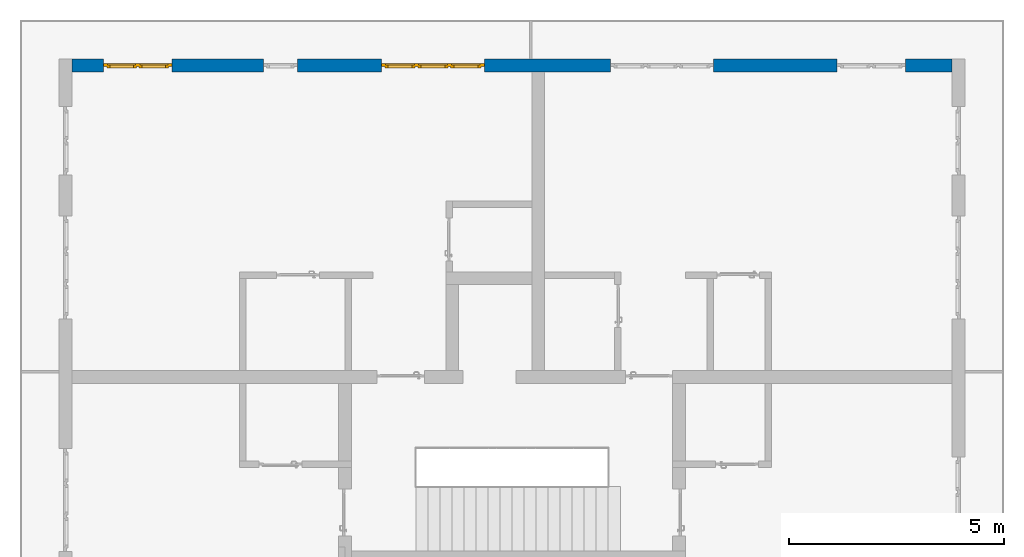
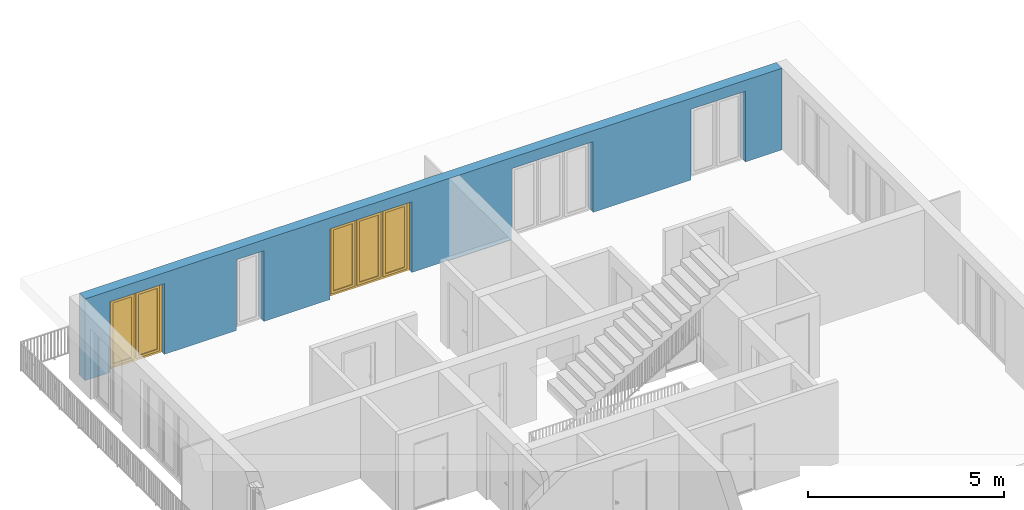
# One storey, part 21 of 48: 2 windows, 1 wall, 5 openings.
"""IFC4 building model written with IfcOpenShell, lengths in metres."""

import ifcopenshell
import ifcopenshell.guid

model = None  # the IFC model being written
_history = None  # IfcOwnerHistory: only IFC2X3 demands one
_inside = {}  # id of a spatial element -> (the spatial element, [elements in it])
_under = {}  # id of a project, library or spatial element -> (it, [spatial elements below it])
_declared = {}  # id of a project -> (the project, [libraries it declares])
_typed = {}  # id of a type object -> (the type object, [elements of that type])
_made_of = {}  # id of a material, layer set ... -> (it, [elements and type objects made of it])


def new_model(schema):
    """Start an empty IFC model of exactly this schema.

    Asked for "IFC4X3", IfcOpenShell would pick the latest addendum, in which some entities
    have other attributes; the version numbers below select the first issue.
    IFC2X3 requires an IfcOwnerHistory on every rooted entity: one is made here for all.
    """
    global model, _history
    if schema == "IFC4X3":
        model = ifcopenshell.file(schema_version=(4, 3, 0, 0))
    else:
        model = ifcopenshell.file(schema=schema)
    _inside.clear()
    _under.clear()
    _declared.clear()
    _typed.clear()
    _made_of.clear()
    _history = None
    if model.schema == "IFC2X3":
        org = make("IfcOrganization", Name="unknown")
        user = make(
            "IfcPersonAndOrganization",
            ThePerson=make("IfcPerson", FamilyName="unknown"),
            TheOrganization=org,
        )
        app = make(
            "IfcApplication",
            ApplicationDeveloper=org,
            Version="unknown",
            ApplicationFullName="unknown",
            ApplicationIdentifier="unknown",
        )
        _history = make(
            "IfcOwnerHistory",
            OwningUser=user,
            OwningApplication=app,
            ChangeAction="ADDED",
            CreationDate=0,
        )
    return model


def make(cls, **values):
    """One entity of the class cls with the attributes given. An attribute that is None is left unset."""
    return model.create_entity(
        cls, **{name: value for name, value in values.items() if value is not None}
    )


def entity(cls, *values):
    """Any entity or typed value of the class cls, its attributes in the order of the schema. None: left unset."""
    e = model.create_entity(cls)
    for i, value in enumerate(values):
        if value is not None:
            e[i] = value
    return e


def rooted(cls, **values):
    """An entity with a GlobalId (a new one), such as an element, a storey or a relation."""
    return make(cls, GlobalId=ifcopenshell.guid.new(), OwnerHistory=_history, **values)


def si_unit(unit_type, name, prefix=None):
    """IfcSIUnit, for example si_unit("LENGTHUNIT", "METRE", prefix="MILLI")."""
    return make("IfcSIUnit", UnitType=unit_type, Prefix=prefix, Name=name)


def converted_unit(unit_type, name, factor, base, dimensions=None, offset=None):
    """IfcConversionBasedUnit, such as the inch: factor (a typed value) times the base unit."""
    return make(
        "IfcConversionBasedUnit"
        if offset is None
        else "IfcConversionBasedUnitWithOffset",
        ConversionOffset=offset,
        Dimensions=None
        if dimensions is None
        else entity("IfcDimensionalExponents", *dimensions),
        UnitType=unit_type,
        Name=name,
        ConversionFactor=make(
            "IfcMeasureWithUnit", ValueComponent=factor, UnitComponent=base
        ),
    )


def derived_unit(unit_type, elements):
    """IfcDerivedUnit: a product of units, each with its exponent."""
    return make(
        "IfcDerivedUnit",
        Elements=[
            make("IfcDerivedUnitElement", Unit=unit, Exponent=power)
            for unit, power in elements
        ],
        UnitType=unit_type,
    )


def assignment(units):
    """IfcUnitAssignment: the units of a project."""
    return None if units is None else make("IfcUnitAssignment", Units=units)


def point(xyz):
    """IfcCartesianPoint."""
    return None if xyz is None else make("IfcCartesianPoint", Coordinates=xyz)


def direction(xyz):
    """IfcDirection."""
    return None if xyz is None else make("IfcDirection", DirectionRatios=xyz)


def frame(location, z_axis=None, x_axis=None):
    """IfcAxis2Placement3D, a coordinate frame: its origin and axes. An axis left out is left unset."""
    return make(
        "IfcAxis2Placement3D",
        Location=point(location),
        Axis=direction(z_axis),
        RefDirection=direction(x_axis),
    )


def origin_with_axes():
    """The frame at (0, 0, 0) with the z axis (0, 0, 1) and the x axis (1, 0, 0) written out."""
    return frame((0.0, 0.0, 0.0), z_axis=(0.0, 0.0, 1.0), x_axis=(1.0, 0.0, 0.0))


def place(relative_to, where):
    """IfcLocalPlacement: puts the frame where relative to a parent placement (None: the world)."""
    return make(
        "IfcLocalPlacement", PlacementRelTo=relative_to, RelativePlacement=where
    )


def context(
    kind, dimensions, precision=None, world=None, true_north=None, identifier=None
):
    """IfcGeometricRepresentationContext, for example the 3D "Model" context."""
    return make(
        "IfcGeometricRepresentationContext",
        ContextIdentifier=identifier,
        ContextType=kind,
        CoordinateSpaceDimension=dimensions,
        Precision=precision,
        WorldCoordinateSystem=world,
        TrueNorth=true_north,
    )


def subcontext(parent, identifier, kind, view, scale=None):
    """IfcGeometricRepresentationSubContext, for example "Body" below "Model"."""
    return make(
        "IfcGeometricRepresentationSubContext",
        ContextIdentifier=identifier,
        ContextType=kind,
        ParentContext=parent,
        TargetScale=scale,
        TargetView=view,
    )


def project(units=None, contexts=None):
    """IfcProject with its units and contexts."""
    return rooted(
        "IfcProject",
        Name="project",
        RepresentationContexts=contexts,
        UnitsInContext=assignment(units),
    )


def spatial(cls, under=None, at=None, **own):
    """A site, building, storey or space (cls), placed at a placement, below another one or the project."""
    s = rooted(cls, ObjectPlacement=at, **own)
    if under is not None:
        _under.setdefault(under.id(), (under, []))[1].append(s)
    return s


def point_list(points):
    """IfcCartesianPointList2D or 3D."""
    cls = (
        "IfcCartesianPointList2D" if len(points[0]) == 2 else "IfcCartesianPointList3D"
    )
    return make(cls, CoordList=points)


def polygons(points, faces, closed=None, point_numbers=None):
    """IfcPolygonalFaceSet: a face is its outer loop, then its inner loops; points numbered from 1."""
    made = []
    for loops in faces:
        if len(loops) == 1:
            made.append(make("IfcIndexedPolygonalFace", CoordIndex=loops[0]))
        else:
            made.append(
                make(
                    "IfcIndexedPolygonalFaceWithVoids",
                    CoordIndex=loops[0],
                    InnerCoordIndices=loops[1:],
                )
            )
    return make(
        "IfcPolygonalFaceSet",
        Coordinates=point_list(points),
        Closed=closed,
        Faces=made,
        PnIndex=point_numbers,
    )


def shape(context_of_items, identifier, shape_type, items):
    """IfcShapeRepresentation: the items that make up one representation, for example the "Body"."""
    return make(
        "IfcShapeRepresentation",
        ContextOfItems=context_of_items,
        RepresentationIdentifier=identifier,
        RepresentationType=shape_type,
        Items=items,
    )


def source(mapping_origin, context_of_items, identifier, shape_type, items):
    """IfcRepresentationMap: a shape defined once, which mapped items show again and again."""
    return make(
        "IfcRepresentationMap",
        MappingOrigin=mapping_origin,
        MappedRepresentation=shape(context_of_items, identifier, shape_type, items),
    )


def transform(
    local_origin,
    x_axis=None,
    y_axis=None,
    z_axis=None,
    scale=None,
    scale2=None,
    scale3=None,
    uniform=True,
):
    """IfcCartesianTransformationOperator3D, or its non-uniform kind. x_axis, y_axis, z_axis: its Axis1, 2, 3."""
    if uniform:
        return make(
            "IfcCartesianTransformationOperator3D",
            Axis1=direction(x_axis),
            Axis2=direction(y_axis),
            LocalOrigin=point(local_origin),
            Scale=scale,
            Axis3=direction(z_axis),
        )
    return make(
        "IfcCartesianTransformationOperator3DnonUniform",
        Axis1=direction(x_axis),
        Axis2=direction(y_axis),
        LocalOrigin=point(local_origin),
        Scale=scale,
        Axis3=direction(z_axis),
        Scale2=scale2,
        Scale3=scale3,
    )


def mapped(mapping_source, mapping_target):
    """IfcMappedItem: shows the shape of a source again, moved by a transform."""
    return make(
        "IfcMappedItem", MappingSource=mapping_source, MappingTarget=mapping_target
    )


def material(Name=None, Category=None):
    """IfcMaterial."""
    return make("IfcMaterial", Name=Name, Category=Category)


def made_of(thing, what):
    """Note that an element or type object is made of a material, layer set ...; save() writes the relation."""
    if what is not None:
        _made_of.setdefault(what.id(), (what, []))[1].append(thing)
    return thing


def type_object(cls, material=None, **own):
    """A type object (cls), such as IfcWallType, which elements share."""
    return made_of(rooted(cls, **own), material)


def element(
    cls,
    number,
    at=None,
    inside=None,
    cuts=None,
    type_object=None,
    material=None,
    context=None,
    identifier="Body",
    shape_type=None,
    held_by="IfcProductDefinitionShape",
    body=None,
    shapes=None,
    **own,
):
    """One element of the class cls, such as IfcWall. Its Tag is "e" and its number.

    at: its placement. inside: the storey or other place that contains it. cuts: it is an
    opening in that element (IfcRelVoidsElement). A single representation is given by context,
    identifier, shape_type and body (its items); several are given by shapes. held_by: the class
    of the entity that holds the representations. save() writes the other relations.
    """
    e = rooted(cls, Tag="e%d" % number, ObjectPlacement=at, **own)
    if body is not None:
        shapes = [shape(context, identifier, shape_type, body)]
    if shapes is not None:
        e.Representation = make(held_by, Representations=shapes)
    if inside is not None:
        _inside.setdefault(inside.id(), (inside, []))[1].append(e)
    if cuts is not None:
        rooted(
            "IfcRelVoidsElement", RelatingBuildingElement=cuts, RelatedOpeningElement=e
        )
    if type_object is not None:
        _typed.setdefault(type_object.id(), (type_object, []))[1].append(e)
    return made_of(e, material)


def fill(opening, filler):
    """IfcRelFillsElement: the door or window that sits in an opening."""
    return rooted(
        "IfcRelFillsElement",
        RelatingOpeningElement=opening,
        RelatedBuildingElement=filler,
    )


def aggregate(whole, parts):
    """IfcRelAggregates: a whole, such as a stair, and the parts it consists of."""
    return rooted("IfcRelAggregates", RelatingObject=whole, RelatedObjects=parts)


def save(model, path):
    """Write the relations noted so far, then the file.

    IfcRelAggregates (storeys below a building ...), IfcRelContainedInSpatialStructure (elements
    in a storey), IfcRelDefinesByType, IfcRelAssociatesMaterial and IfcRelDeclares: one each for
    every whole, place, type object, material and project.
    """
    for whole, parts in _under.values():
        aggregate(whole, parts)
    for where, things in _inside.values():
        rooted(
            "IfcRelContainedInSpatialStructure",
            RelatedElements=things,
            RelatingStructure=where,
        )
    for kind, things in _typed.values():
        rooted("IfcRelDefinesByType", RelatedObjects=things, RelatingType=kind)
    for what, things in _made_of.values():
        rooted("IfcRelAssociatesMaterial", RelatedObjects=things, RelatingMaterial=what)
    for by, libraries in _declared.values():
        rooted("IfcRelDeclares", RelatingContext=by, RelatedDefinitions=libraries)
    model.write(path)


model = new_model("IFC4")

# Units and contexts
model_context = context("Model", 3, precision=1e-05, world=origin_with_axes(), true_north=direction((0.0, 1.0)))
body_context = subcontext(model_context, "Body", "Model", "MODEL_VIEW")
ifc_project = project(units=[si_unit("LENGTHUNIT", "METRE"), si_unit("AREAUNIT", "SQUARE_METRE"), si_unit("VOLUMEUNIT", "CUBIC_METRE"), converted_unit("PLANEANGLEUNIT", "DEGREE", entity("IfcPlaneAngleMeasure", 0.0174532925199), si_unit("PLANEANGLEUNIT", "RADIAN"), dimensions=[0, 0, 0, 0, 0, 0, 0]), converted_unit("TIMEUNIT", "Year", entity("IfcTimeMeasure", 31556926.0), si_unit("TIMEUNIT", "SECOND"), dimensions=[0, 0, 1, 0, 0, 0, 0]), si_unit("MASSUNIT", "GRAM", prefix="KILO"), si_unit("THERMODYNAMICTEMPERATUREUNIT", "DEGREE_CELSIUS"), si_unit("LUMINOUSINTENSITYUNIT", "LUMEN"), si_unit("ENERGYUNIT", "JOULE", prefix="MEGA"), derived_unit("THERMALCONDUCTANCEUNIT", [(si_unit("POWERUNIT", "WATT"), 1), (si_unit("LENGTHUNIT", "METRE"), -1), (si_unit("THERMODYNAMICTEMPERATUREUNIT", "KELVIN"), -1)]), derived_unit("SPECIFICHEATCAPACITYUNIT", [(si_unit("ENERGYUNIT", "JOULE"), 1), (si_unit("MASSUNIT", "GRAM", prefix="KILO"), -1), (si_unit("THERMODYNAMICTEMPERATUREUNIT", "KELVIN"), -1)]), derived_unit("MASSDENSITYUNIT", [(si_unit("MASSUNIT", "GRAM", prefix="KILO"), 1), (si_unit("VOLUMEUNIT", "CUBIC_METRE"), -1)])], contexts=[model_context])

# Site, building, storey
site_placement = place(None, origin_with_axes())
site = spatial("IfcSite", under=ifc_project, at=site_placement, CompositionType="ELEMENT")
building_placement = place(site_placement, origin_with_axes())
building = spatial("IfcBuilding", under=site, at=building_placement, CompositionType="ELEMENT")
storey_placement = place(building_placement, frame((0.0, 0.0, 3.4), z_axis=(0.0, 0.0, 1.0), x_axis=(1.0, 0.0, 0.0)))
storey = spatial("IfcBuildingStorey", under=building, at=storey_placement, Name="1. Geschoss", CompositionType="ELEMENT", Elevation=3.4)

# Wall, openings, windows
ifc_material = material()
wall_type = type_object("IfcWallType", Name="300", PredefinedType="NOTDEFINED")
wall_placement = place(storey_placement, frame((-11.7421993804, 8.92118776896, 0.0), z_axis=(0.0, 0.0, 1.0), x_axis=(1.0, 0.0, 0.0)))
wall = element("IfcWall", 1, at=wall_placement, inside=storey, type_object=wall_type, material=ifc_material, Name="Wand-001", PredefinedType="NOTDEFINED", context=body_context, shape_type="Tessellation", body=[
    polygons([(15.23, -0.1, 0.0), (15.23, -0.3, 0.0), (15.23, -0.3, 2.2), (15.23, 0.0, 2.2), (15.23, 0.0, 0.0), (18.102139809, 0.0, 0.0), (18.102139809, -0.3, 0.0), (18.102139809, -0.3, 2.2), (19.702139809, -0.3, 2.2), (19.702139809, -0.3, 0.0), (20.78, -0.3, 0.0), (20.78, -0.3, 2.54), (0.3, -0.3, 2.54), (0.3, -0.3, 0.0), (1.0288518641, -0.3, 0.0), (1.0288518641, -0.3, 2.2), (2.6288518641, -0.3, 2.2), (2.6288518641, -0.3, 0.0), (4.75, -0.3, 0.0), (4.75, -0.3, 2.2), (5.55, -0.3, 2.2), (5.55, -0.3, 0.0), (7.50089858046, -0.3, 0.0), (7.50089858046, -0.3, 2.2), (9.90089858046, -0.3, 2.2), (9.90089858046, -0.3, 0.0), (12.83, -0.3, 0.0), (12.83, -0.3, 2.2), (12.83, 0.0, 2.2), (12.83, 0.0, 0.0), (9.90089858046, 0.0, 0.0), (9.90089858046, 0.0, 2.2), (7.50089858046, 0.0, 2.2), (7.50089858046, 0.0, 0.0), (5.55, 0.0, 0.0), (5.55, 0.0, 2.2), (4.75, 0.0, 2.2), (4.75, 0.0, 0.0), (2.6288518641, 0.0, 0.0), (2.6288518641, 0.0, 2.2), (1.0288518641, 0.0, 2.2), (1.0288518641, 0.0, 0.0), (0.3, 0.0, 0.0), (0.3, 0.0, 2.54), (20.78, 0.0, 2.54), (20.78, 0.0, 0.0), (19.702139809, 0.0, 0.0), (19.702139809, 0.0, 2.2), (18.102139809, 0.0, 2.2), (12.83, -0.1, 0.0)], [[[1, 2, 3, 4, 5]], [[2, 1, 5, 6, 7]], [[3, 2, 7, 8, 9, 10, 11, 12, 13, 14, 15, 16, 17, 18, 19, 20, 21, 22, 23, 24, 25, 26, 27, 28]], [[4, 3, 28, 29]], [[6, 5, 4, 29, 30, 31, 32, 33, 34, 35, 36, 37, 38, 39, 40, 41, 42, 43, 44, 45, 46, 47, 48, 49]], [[6, 49, 8, 7]], [[8, 49, 48, 9]], [[48, 47, 10, 9]], [[46, 11, 10, 47]], [[12, 11, 46, 45]], [[45, 44, 13, 12]], [[44, 43, 14, 13]], [[15, 14, 43, 42]], [[16, 15, 42, 41]], [[40, 17, 16, 41]], [[18, 17, 40, 39]], [[19, 18, 39, 38]], [[20, 19, 38, 37]], [[36, 21, 20, 37]], [[22, 21, 36, 35]], [[22, 35, 34, 23]], [[34, 33, 24, 23]], [[24, 33, 32, 25]], [[32, 31, 26, 25]], [[50, 27, 26, 31, 30]], [[28, 27, 50, 30, 29]]], closed=True),
])
opening_1_placement = place(wall_placement, frame((1.8288518641, 0.0, 0.0), z_axis=(0.0, 0.0, 1.0), x_axis=(1.0, 0.0, 0.0)))
opening_1 = element("IfcOpeningElement", 2, at=opening_1_placement, cuts=wall, Name="Fenster-001", context=body_context, identifier="Reference", shape_type="Tessellation", body=[
    polygons([(-0.8, -0.1, 0.0), (-0.8, -0.1, 2.2), (-0.8, 0.000999999999998, 2.2), (-0.8, 0.000999999999998, 0.0), (-0.8, -0.301, 0.0), (-0.8, -0.301, 2.2), (0.8, -0.1, 2.2), (0.8, 0.000999999999999, 2.2), (0.8, -0.301, 2.2), (0.8, 0.000999999999999, 0.0), (0.8, -0.1, 0.0), (0.8, -0.301, 0.0)], [[[1, 2, 3, 4]], [[2, 1, 5, 6]], [[7, 8, 3, 2, 6, 9]], [[8, 10, 4, 3]], [[1, 4, 10, 11, 12, 5]], [[6, 5, 12, 9]], [[7, 11, 10, 8]], [[11, 7, 9, 12]]], closed=True),
])
opening_2_placement = place(wall_placement, frame((8.70089858046, 0.0, 0.0), z_axis=(0.0, 0.0, 1.0), x_axis=(1.0, 0.0, 0.0)))
opening_2 = element("IfcOpeningElement", 3, at=opening_2_placement, cuts=wall, Name="Fenster-002", context=body_context, identifier="Reference", shape_type="Tessellation", body=[
    polygons([(-1.2, -0.1, 0.0), (-1.2, -0.1, 2.2), (-1.2, 0.000999999999999, 2.2), (-1.2, 0.000999999999999, 0.0), (-1.2, -0.301, 0.0), (-1.2, -0.301, 2.2), (1.2, -0.1, 2.2), (1.2, 0.001, 2.2), (1.2, -0.301, 2.2), (1.2, 0.001, 0.0), (1.2, -0.1, 0.0), (1.2, -0.301, 0.0)], [[[1, 2, 3, 4]], [[2, 1, 5, 6]], [[7, 8, 3, 2, 6, 9]], [[8, 10, 4, 3]], [[1, 4, 10, 11, 12, 5]], [[6, 5, 12, 9]], [[7, 11, 10, 8]], [[11, 7, 9, 12]]], closed=True),
])
opening_3_placement = place(wall_placement, frame((5.15, 0.0, 0.0), z_axis=(0.0, 0.0, 1.0), x_axis=(1.0, 0.0, 0.0)))
element("IfcOpeningElement", 4, at=opening_3_placement, cuts=wall, Name="Fenster-003", context=body_context, identifier="Reference", shape_type="Tessellation", body=[
    polygons([(-0.4, -0.1, 0.0), (-0.4, -0.1, 2.2), (-0.4, 0.001, 2.2), (-0.4, 0.001, 0.0), (-0.4, -0.301, 0.0), (-0.4, -0.301, 2.2), (0.4, -0.1, 2.2), (0.4, 0.001, 2.2), (0.4, -0.301, 2.2), (0.4, 0.001, 0.0), (0.4, -0.1, 0.0), (0.4, -0.301, 0.0)], [[[1, 2, 3, 4]], [[2, 1, 5, 6]], [[7, 8, 3, 2, 6, 9]], [[8, 10, 4, 3]], [[1, 4, 10, 11, 12, 5]], [[6, 5, 12, 9]], [[7, 11, 10, 8]], [[11, 7, 9, 12]]], closed=True),
])
opening_4_placement = place(wall_placement, frame((18.902139809, 0.0, 0.0), z_axis=(0.0, 0.0, 1.0), x_axis=(1.0, 0.0, 0.0)))
element("IfcOpeningElement", 5, at=opening_4_placement, cuts=wall, Name="Fenster-001", context=body_context, identifier="Reference", shape_type="Tessellation", body=[
    polygons([(-0.8, -0.1, 0.0), (-0.8, -0.1, 2.2), (-0.8, 0.001, 2.2), (-0.8, 0.001, 0.0), (-0.8, -0.301, 0.0), (-0.8, -0.301, 2.2), (0.8, -0.1, 2.2), (0.8, 0.001, 2.2), (0.8, -0.301, 2.2), (0.8, 0.001, 0.0), (0.8, -0.1, 0.0), (0.8, -0.301, 0.0)], [[[1, 2, 3, 4]], [[2, 1, 5, 6]], [[7, 8, 3, 2, 6, 9]], [[8, 10, 4, 3]], [[1, 4, 10, 11, 12, 5]], [[6, 5, 12, 9]], [[7, 11, 10, 8]], [[11, 7, 9, 12]]], closed=True),
])
opening_5_placement = place(wall_placement, frame((14.03, 0.0, 0.0), z_axis=(0.0, 0.0, 1.0), x_axis=(1.0, 0.0, 0.0)))
element("IfcOpeningElement", 6, at=opening_5_placement, cuts=wall, Name="Fenster-002", context=body_context, identifier="Reference", shape_type="Tessellation", body=[
    polygons([(-1.2, -0.1, 0.0), (-1.2, -0.1, 2.2), (-1.2, 0.001, 2.2), (-1.2, 0.001, 0.0), (-1.2, -0.301, 0.0), (-1.2, -0.301, 2.2), (1.2, -0.1, 2.2), (1.2, 0.001, 2.2), (1.2, -0.301, 2.2), (1.2, 0.001, 0.0), (1.2, -0.1, 0.0), (1.2, -0.301, 0.0)], [[[1, 2, 3, 4]], [[2, 1, 5, 6]], [[7, 8, 3, 2, 6, 9]], [[8, 10, 4, 3]], [[1, 4, 10, 11, 12, 5]], [[6, 5, 12, 9]], [[7, 11, 10, 8]], [[11, 7, 9, 12]]], closed=True),
])
window_type_1 = type_object("IfcWindowType", Name="2-1+1 26", PartitioningType="DOUBLE_PANEL_VERTICAL", PredefinedType="WINDOW")
shared_shape_1 = source(origin_with_axes(), body_context, "Body", "Tessellation", [
    polygons([(0.8, -0.07, 0.0), (0.7, -0.07, 0.1), (0.7, 0.0, 0.1), (0.8, 0.0, 0.0), (0.8, -0.07, 2.2), (0.7, -0.07, 2.1), (0.7, 0.0, 2.1), (0.8, 0.0, 2.2)], [[[1, 2, 3, 4]], [[1, 5, 6, 2]], [[2, 6, 7, 3]], [[4, 3, 7, 8]], [[5, 1, 4, 8]], [[6, 5, 8, 7]]], closed=True),
    polygons([(-0.8, -0.07, 0.0), (-0.8, -0.07, 2.2), (-0.8, 0.0, 2.2), (-0.8, 0.0, 0.0), (-0.7, -0.07, 0.1), (-0.7, -0.07, 2.1), (-0.7, 0.0, 2.1), (-0.7, 0.0, 0.1)], [[[1, 2, 3, 4]], [[1, 5, 6, 2]], [[2, 6, 7, 3]], [[4, 3, 7, 8]], [[5, 1, 4, 8]], [[6, 5, 8, 7]]], closed=True),
    polygons([(0.8, -0.07, 0.0), (-0.8, -0.07, 0.0), (-0.8, 0.0, 0.0), (0.8, 0.0, 0.0), (0.7, -0.07, 0.1), (0.05, -0.07, 0.1), (-0.05, -0.07, 0.1), (-0.7, -0.07, 0.1), (-0.7, 0.0, 0.1), (-0.05, 0.0, 0.1), (0.05, 0.0, 0.1), (0.7, 0.0, 0.1)], [[[1, 2, 3, 4]], [[1, 5, 6, 7, 8, 2]], [[2, 8, 9, 3]], [[4, 3, 9, 10, 11, 12]], [[5, 1, 4, 12]], [[6, 5, 12, 11]], [[7, 6, 11, 10]], [[8, 7, 10, 9]]], closed=True),
    polygons([(0.8, -0.07, 2.2), (0.7, -0.07, 2.1), (0.7, 0.0, 2.1), (0.8, 0.0, 2.2), (-0.8, -0.07, 2.2), (-0.7, -0.07, 2.1), (-0.05, -0.07, 2.1), (0.05, -0.07, 2.1), (0.05, 0.0, 2.1), (-0.05, 0.0, 2.1), (-0.7, 0.0, 2.1), (-0.8, 0.0, 2.2)], [[[1, 2, 3, 4]], [[1, 5, 6, 7, 8, 2]], [[2, 8, 9, 3]], [[4, 3, 9, 10, 11, 12]], [[5, 1, 4, 12]], [[6, 5, 12, 11]], [[7, 6, 11, 10]], [[8, 7, 10, 9]]], closed=True),
    polygons([(0.05, -0.07, 0.1), (-0.05, -0.07, 0.1), (-0.05, 0.0, 0.1), (0.05, 0.0, 0.1), (0.05, -0.07, 2.1), (-0.05, -0.07, 2.1), (-0.05, 0.0, 2.1), (0.05, 0.0, 2.1)], [[[1, 2, 3, 4]], [[1, 5, 6, 2]], [[2, 6, 7, 3]], [[4, 3, 7, 8]], [[5, 1, 4, 8]], [[6, 5, 8, 7]]], closed=True),
    polygons([(0.72, 0.0, 0.08), (0.65, 0.0, 0.15), (0.65, 0.03, 0.15), (0.72, 0.03, 0.08), (0.72, 0.0, 2.12), (0.65, 0.0, 2.05), (0.65, 0.03, 2.05), (0.72, 0.03, 2.12)], [[[1, 2, 3, 4]], [[1, 5, 6, 2]], [[2, 6, 7, 3]], [[4, 3, 7, 8]], [[5, 1, 4, 8]], [[6, 5, 8, 7]]], closed=True),
    polygons([(0.03, 0.0, 0.08), (0.03, 0.03, 0.08), (0.1, 0.03, 0.15), (0.1, 0.0, 0.15), (0.03, 0.0, 2.12), (0.03, 0.03, 2.12), (0.1, 0.03, 2.05), (0.1, 0.0, 2.05)], [[[1, 2, 3, 4]], [[5, 6, 2, 1]], [[2, 6, 7, 3]], [[4, 3, 7, 8]], [[1, 4, 8, 5]], [[8, 7, 6, 5]]], closed=True),
    polygons([(0.72, 0.0, 0.08), (0.03, 0.0, 0.08), (0.03, 0.03, 0.08), (0.72, 0.03, 0.08), (0.65, 0.0, 0.15), (0.1, 0.0, 0.15), (0.1, 0.03, 0.15), (0.65, 0.03, 0.15)], [[[1, 2, 3, 4]], [[1, 5, 6, 2]], [[2, 6, 7, 3]], [[4, 3, 7, 8]], [[5, 1, 4, 8]], [[6, 5, 8, 7]]], closed=True),
    polygons([(0.72, 0.0, 2.12), (0.72, 0.03, 2.12), (0.03, 0.03, 2.12), (0.03, 0.0, 2.12), (0.65, 0.0, 2.05), (0.65, 0.03, 2.05), (0.1, 0.03, 2.05), (0.1, 0.0, 2.05)], [[[1, 2, 3, 4]], [[5, 6, 2, 1]], [[2, 6, 7, 3]], [[4, 3, 7, 8]], [[1, 4, 8, 5]], [[8, 7, 6, 5]]], closed=True),
    polygons([(0.7, -0.03, 0.1), (0.65, -0.03, 0.15), (0.65, 0.0, 0.15), (0.7, 0.0, 0.1), (0.7, -0.03, 2.1), (0.65, -0.03, 2.05), (0.65, 0.0, 2.05), (0.7, 0.0, 2.1)], [[[1, 2, 3, 4]], [[1, 5, 6, 2]], [[2, 6, 7, 3]], [[4, 3, 7, 8]], [[5, 1, 4, 8]], [[6, 5, 8, 7]]], closed=True),
    polygons([(0.05, -0.03, 0.1), (0.05, 0.0, 0.1), (0.1, 0.0, 0.15), (0.1, -0.03, 0.15), (0.05, -0.03, 2.1), (0.05, 0.0, 2.1), (0.1, 0.0, 2.05), (0.1, -0.03, 2.05)], [[[1, 2, 3, 4]], [[5, 6, 2, 1]], [[2, 6, 7, 3]], [[4, 3, 7, 8]], [[1, 4, 8, 5]], [[8, 7, 6, 5]]], closed=True),
    polygons([(0.7, -0.03, 0.1), (0.05, -0.03, 0.1), (0.05, 0.0, 0.1), (0.7, 0.0, 0.1), (0.65, -0.03, 0.15), (0.1, -0.03, 0.15), (0.1, 0.0, 0.15), (0.65, 0.0, 0.15)], [[[1, 2, 3, 4]], [[1, 5, 6, 2]], [[2, 6, 7, 3]], [[4, 3, 7, 8]], [[5, 1, 4, 8]], [[6, 5, 8, 7]]], closed=True),
    polygons([(0.7, -0.03, 2.1), (0.7, 0.0, 2.1), (0.05, 0.0, 2.1), (0.05, -0.03, 2.1), (0.65, -0.03, 2.05), (0.65, 0.0, 2.05), (0.1, 0.0, 2.05), (0.1, -0.03, 2.05)], [[[1, 2, 3, 4]], [[5, 6, 2, 1]], [[2, 6, 7, 3]], [[4, 3, 7, 8]], [[1, 4, 8, 5]], [[8, 7, 6, 5]]], closed=True),
    polygons([(0.65, -0.005, 0.15), (0.1, -0.005, 0.15), (0.1, 0.005, 0.15), (0.65, 0.005, 0.15), (0.65, -0.005, 2.05), (0.1, -0.005, 2.05), (0.1, 0.005, 2.05), (0.65, 0.005, 2.05)], [[[1, 2, 3, 4]], [[1, 5, 6, 2]], [[2, 6, 7, 3]], [[4, 3, 7, 8]], [[5, 1, 4, 8]], [[6, 5, 8, 7]]], closed=True),
    polygons([(-0.03, 0.0, 0.08), (-0.1, 0.0, 0.15), (-0.1, 0.03, 0.15), (-0.03, 0.03, 0.08), (-0.03, 0.0, 2.12), (-0.1, 0.0, 2.05), (-0.1, 0.03, 2.05), (-0.03, 0.03, 2.12)], [[[1, 2, 3, 4]], [[1, 5, 6, 2]], [[2, 6, 7, 3]], [[4, 3, 7, 8]], [[5, 1, 4, 8]], [[6, 5, 8, 7]]], closed=True),
    polygons([(-0.72, 0.0, 0.08), (-0.72, 0.03, 0.08), (-0.65, 0.03, 0.15), (-0.65, 0.0, 0.15), (-0.72, 0.0, 2.12), (-0.72, 0.03, 2.12), (-0.65, 0.03, 2.05), (-0.65, 0.0, 2.05)], [[[1, 2, 3, 4]], [[5, 6, 2, 1]], [[2, 6, 7, 3]], [[4, 3, 7, 8]], [[1, 4, 8, 5]], [[8, 7, 6, 5]]], closed=True),
    polygons([(-0.03, 0.0, 0.08), (-0.72, 0.0, 0.08), (-0.72, 0.03, 0.08), (-0.03, 0.03, 0.08), (-0.1, 0.0, 0.15), (-0.65, 0.0, 0.15), (-0.65, 0.03, 0.15), (-0.1, 0.03, 0.15)], [[[1, 2, 3, 4]], [[1, 5, 6, 2]], [[2, 6, 7, 3]], [[4, 3, 7, 8]], [[5, 1, 4, 8]], [[6, 5, 8, 7]]], closed=True),
    polygons([(-0.03, 0.0, 2.12), (-0.03, 0.03, 2.12), (-0.72, 0.03, 2.12), (-0.72, 0.0, 2.12), (-0.1, 0.0, 2.05), (-0.1, 0.03, 2.05), (-0.65, 0.03, 2.05), (-0.65, 0.0, 2.05)], [[[1, 2, 3, 4]], [[5, 6, 2, 1]], [[2, 6, 7, 3]], [[4, 3, 7, 8]], [[1, 4, 8, 5]], [[8, 7, 6, 5]]], closed=True),
    polygons([(-0.05, -0.03, 0.1), (-0.1, -0.03, 0.15), (-0.1, 0.0, 0.15), (-0.05, 0.0, 0.1), (-0.05, -0.03, 2.1), (-0.1, -0.03, 2.05), (-0.1, 0.0, 2.05), (-0.05, 0.0, 2.1)], [[[1, 2, 3, 4]], [[1, 5, 6, 2]], [[2, 6, 7, 3]], [[4, 3, 7, 8]], [[5, 1, 4, 8]], [[6, 5, 8, 7]]], closed=True),
    polygons([(-0.7, -0.03, 0.1), (-0.7, 0.0, 0.1), (-0.65, 0.0, 0.15), (-0.65, -0.03, 0.15), (-0.7, -0.03, 2.1), (-0.7, 0.0, 2.1), (-0.65, 0.0, 2.05), (-0.65, -0.03, 2.05)], [[[1, 2, 3, 4]], [[5, 6, 2, 1]], [[2, 6, 7, 3]], [[4, 3, 7, 8]], [[1, 4, 8, 5]], [[8, 7, 6, 5]]], closed=True),
    polygons([(-0.05, -0.03, 0.1), (-0.7, -0.03, 0.1), (-0.7, 0.0, 0.1), (-0.05, 0.0, 0.1), (-0.1, -0.03, 0.15), (-0.65, -0.03, 0.15), (-0.65, 0.0, 0.15), (-0.1, 0.0, 0.15)], [[[1, 2, 3, 4]], [[1, 5, 6, 2]], [[2, 6, 7, 3]], [[4, 3, 7, 8]], [[5, 1, 4, 8]], [[6, 5, 8, 7]]], closed=True),
    polygons([(-0.05, -0.03, 2.1), (-0.05, 0.0, 2.1), (-0.7, 0.0, 2.1), (-0.7, -0.03, 2.1), (-0.1, -0.03, 2.05), (-0.1, 0.0, 2.05), (-0.65, 0.0, 2.05), (-0.65, -0.03, 2.05)], [[[1, 2, 3, 4]], [[5, 6, 2, 1]], [[2, 6, 7, 3]], [[4, 3, 7, 8]], [[1, 4, 8, 5]], [[8, 7, 6, 5]]], closed=True),
    polygons([(-0.1, -0.005, 0.15), (-0.65, -0.005, 0.15), (-0.65, 0.005, 0.15), (-0.1, 0.005, 0.15), (-0.1, -0.005, 2.05), (-0.65, -0.005, 2.05), (-0.65, 0.005, 2.05), (-0.1, 0.005, 2.05)], [[[1, 2, 3, 4]], [[1, 5, 6, 2]], [[2, 6, 7, 3]], [[4, 3, 7, 8]], [[5, 1, 4, 8]], [[6, 5, 8, 7]]], closed=True),
])
window_1_placement = place(opening_1_placement, frame((0.8, 0.0, 0.0), z_axis=(0.0, 0.0, 1.0), x_axis=(-1.0, 0.0, 0.0)))
window_1 = element("IfcWindow", 7, at=window_1_placement, inside=storey, type_object=window_type_1, Name="Fenster-001", OverallHeight=2.2, OverallWidth=1.6, PredefinedType="WINDOW", context=body_context, shape_type="MappedRepresentation", body=[
    mapped(shared_shape_1, transform((0.8, 0.17, 0.0))),
])
fill(opening_1, window_1)
window_type_2 = type_object("IfcWindowType", Name="3-1+1+1 26", PartitioningType="TRIPLE_PANEL_VERTICAL", PredefinedType="WINDOW")
shared_shape_2 = source(origin_with_axes(), body_context, "Body", "Tessellation", [
    polygons([(1.2, -0.07, 0.0), (1.1, -0.07, 0.1), (1.1, 0.0, 0.1), (1.2, 0.0, 0.0), (1.2, -0.07, 2.2), (1.1, -0.07, 2.1), (1.1, 0.0, 2.1), (1.2, 0.0, 2.2)], [[[1, 2, 3, 4]], [[1, 5, 6, 2]], [[2, 6, 7, 3]], [[4, 3, 7, 8]], [[5, 1, 4, 8]], [[6, 5, 8, 7]]], closed=True),
    polygons([(-1.2, -0.07, 0.0), (-1.2, -0.07, 2.2), (-1.2, 0.0, 2.2), (-1.2, 0.0, 0.0), (-1.1, -0.07, 0.1), (-1.1, -0.07, 2.1), (-1.1, 0.0, 2.1), (-1.1, 0.0, 0.1)], [[[1, 2, 3, 4]], [[1, 5, 6, 2]], [[2, 6, 7, 3]], [[4, 3, 7, 8]], [[5, 1, 4, 8]], [[6, 5, 8, 7]]], closed=True),
    polygons([(1.2, -0.07, 0.0), (-1.2, -0.07, 0.0), (-1.2, 0.0, 0.0), (1.2, 0.0, 0.0), (1.1, -0.07, 0.1), (0.433333333333, -0.07, 0.1), (0.333333333333, -0.07, 0.1), (-0.333333333333, -0.07, 0.1), (-0.433333333333, -0.07, 0.1), (-1.1, -0.07, 0.1), (-1.1, 0.0, 0.1), (-0.433333333333, 0.0, 0.1), (-0.333333333333, 0.0, 0.1), (0.333333333333, 0.0, 0.1), (0.433333333333, 0.0, 0.1), (1.1, 0.0, 0.1)], [[[1, 2, 3, 4]], [[1, 5, 6, 7, 8, 9, 10, 2]], [[2, 10, 11, 3]], [[4, 3, 11, 12, 13, 14, 15, 16]], [[5, 1, 4, 16]], [[6, 5, 16, 15]], [[7, 6, 15, 14]], [[8, 7, 14, 13]], [[9, 8, 13, 12]], [[10, 9, 12, 11]]], closed=True),
    polygons([(1.2, -0.07, 2.2), (1.1, -0.07, 2.1), (1.1, 0.0, 2.1), (1.2, 0.0, 2.2), (-1.2, -0.07, 2.2), (-1.1, -0.07, 2.1), (-0.433333333333, -0.07, 2.1), (-0.333333333333, -0.07, 2.1), (0.333333333333, -0.07, 2.1), (0.433333333333, -0.07, 2.1), (0.433333333333, 0.0, 2.1), (0.333333333333, 0.0, 2.1), (-0.333333333333, 0.0, 2.1), (-0.433333333333, 0.0, 2.1), (-1.1, 0.0, 2.1), (-1.2, 0.0, 2.2)], [[[1, 2, 3, 4]], [[1, 5, 6, 7, 8, 9, 10, 2]], [[2, 10, 11, 3]], [[4, 3, 11, 12, 13, 14, 15, 16]], [[5, 1, 4, 16]], [[6, 5, 16, 15]], [[7, 6, 15, 14]], [[8, 7, 14, 13]], [[9, 8, 13, 12]], [[10, 9, 12, 11]]], closed=True),
    polygons([(-0.333333333333, -0.07, 0.1), (-0.433333333333, -0.07, 0.1), (-0.433333333333, 0.0, 0.1), (-0.333333333333, 0.0, 0.1), (-0.333333333333, -0.07, 2.1), (-0.433333333333, -0.07, 2.1), (-0.433333333333, 0.0, 2.1), (-0.333333333333, 0.0, 2.1)], [[[1, 2, 3, 4]], [[1, 5, 6, 2]], [[2, 6, 7, 3]], [[4, 3, 7, 8]], [[5, 1, 4, 8]], [[6, 5, 8, 7]]], closed=True),
    polygons([(0.433333333333, -0.07, 0.1), (0.333333333333, -0.07, 0.1), (0.333333333333, 0.0, 0.1), (0.433333333333, 0.0, 0.1), (0.433333333333, -0.07, 2.1), (0.333333333333, -0.07, 2.1), (0.333333333333, 0.0, 2.1), (0.433333333333, 0.0, 2.1)], [[[1, 2, 3, 4]], [[1, 5, 6, 2]], [[2, 6, 7, 3]], [[4, 3, 7, 8]], [[5, 1, 4, 8]], [[6, 5, 8, 7]]], closed=True),
    polygons([(1.12, 0.0, 0.08), (1.05, 0.0, 0.15), (1.05, 0.03, 0.15), (1.12, 0.03, 0.08), (1.12, 0.0, 2.12), (1.05, 0.0, 2.05), (1.05, 0.03, 2.05), (1.12, 0.03, 2.12)], [[[1, 2, 3, 4]], [[1, 5, 6, 2]], [[2, 6, 7, 3]], [[4, 3, 7, 8]], [[5, 1, 4, 8]], [[6, 5, 8, 7]]], closed=True),
    polygons([(0.413333333333, 0.0, 0.08), (0.413333333333, 0.03, 0.08), (0.483333333333, 0.03, 0.15), (0.483333333333, 0.0, 0.15), (0.413333333333, 0.0, 2.12), (0.413333333333, 0.03, 2.12), (0.483333333333, 0.03, 2.05), (0.483333333333, 0.0, 2.05)], [[[1, 2, 3, 4]], [[5, 6, 2, 1]], [[2, 6, 7, 3]], [[4, 3, 7, 8]], [[1, 4, 8, 5]], [[8, 7, 6, 5]]], closed=True),
    polygons([(1.12, 0.0, 0.08), (0.413333333333, 0.0, 0.08), (0.413333333333, 0.03, 0.08), (1.12, 0.03, 0.08), (1.05, 0.0, 0.15), (0.483333333333, 0.0, 0.15), (0.483333333333, 0.03, 0.15), (1.05, 0.03, 0.15)], [[[1, 2, 3, 4]], [[1, 5, 6, 2]], [[2, 6, 7, 3]], [[4, 3, 7, 8]], [[5, 1, 4, 8]], [[6, 5, 8, 7]]], closed=True),
    polygons([(1.12, 0.0, 2.12), (1.12, 0.03, 2.12), (0.413333333333, 0.03, 2.12), (0.413333333333, 0.0, 2.12), (1.05, 0.0, 2.05), (1.05, 0.03, 2.05), (0.483333333333, 0.03, 2.05), (0.483333333333, 0.0, 2.05)], [[[1, 2, 3, 4]], [[5, 6, 2, 1]], [[2, 6, 7, 3]], [[4, 3, 7, 8]], [[1, 4, 8, 5]], [[8, 7, 6, 5]]], closed=True),
    polygons([(1.1, -0.03, 0.1), (1.05, -0.03, 0.15), (1.05, 0.0, 0.15), (1.1, 0.0, 0.1), (1.1, -0.03, 2.1), (1.05, -0.03, 2.05), (1.05, 0.0, 2.05), (1.1, 0.0, 2.1)], [[[1, 2, 3, 4]], [[1, 5, 6, 2]], [[2, 6, 7, 3]], [[4, 3, 7, 8]], [[5, 1, 4, 8]], [[6, 5, 8, 7]]], closed=True),
    polygons([(0.433333333333, -0.03, 0.1), (0.433333333333, 0.0, 0.1), (0.483333333333, 0.0, 0.15), (0.483333333333, -0.03, 0.15), (0.433333333333, -0.03, 2.1), (0.433333333333, 0.0, 2.1), (0.483333333333, 0.0, 2.05), (0.483333333333, -0.03, 2.05)], [[[1, 2, 3, 4]], [[5, 6, 2, 1]], [[2, 6, 7, 3]], [[4, 3, 7, 8]], [[1, 4, 8, 5]], [[8, 7, 6, 5]]], closed=True),
    polygons([(1.1, -0.03, 0.1), (0.433333333333, -0.03, 0.1), (0.433333333333, 0.0, 0.1), (1.1, 0.0, 0.1), (1.05, -0.03, 0.15), (0.483333333333, -0.03, 0.15), (0.483333333333, 0.0, 0.15), (1.05, 0.0, 0.15)], [[[1, 2, 3, 4]], [[1, 5, 6, 2]], [[2, 6, 7, 3]], [[4, 3, 7, 8]], [[5, 1, 4, 8]], [[6, 5, 8, 7]]], closed=True),
    polygons([(1.1, -0.03, 2.1), (1.1, 0.0, 2.1), (0.433333333333, 0.0, 2.1), (0.433333333333, -0.03, 2.1), (1.05, -0.03, 2.05), (1.05, 0.0, 2.05), (0.483333333333, 0.0, 2.05), (0.483333333333, -0.03, 2.05)], [[[1, 2, 3, 4]], [[5, 6, 2, 1]], [[2, 6, 7, 3]], [[4, 3, 7, 8]], [[1, 4, 8, 5]], [[8, 7, 6, 5]]], closed=True),
    polygons([(1.05, -0.005, 0.15), (0.483333333333, -0.005, 0.15), (0.483333333333, 0.005, 0.15), (1.05, 0.005, 0.15), (1.05, -0.005, 2.05), (0.483333333333, -0.005, 2.05), (0.483333333333, 0.005, 2.05), (1.05, 0.005, 2.05)], [[[1, 2, 3, 4]], [[1, 5, 6, 2]], [[2, 6, 7, 3]], [[4, 3, 7, 8]], [[5, 1, 4, 8]], [[6, 5, 8, 7]]], closed=True),
    polygons([(0.353333333333, 0.0, 0.08), (0.283333333333, 0.0, 0.15), (0.283333333333, 0.03, 0.15), (0.353333333333, 0.03, 0.08), (0.353333333333, 0.0, 2.12), (0.283333333333, 0.0, 2.05), (0.283333333333, 0.03, 2.05), (0.353333333333, 0.03, 2.12)], [[[1, 2, 3, 4]], [[1, 5, 6, 2]], [[2, 6, 7, 3]], [[4, 3, 7, 8]], [[5, 1, 4, 8]], [[6, 5, 8, 7]]], closed=True),
    polygons([(-0.353333333333, 0.0, 0.08), (-0.353333333333, 0.03, 0.08), (-0.283333333333, 0.03, 0.15), (-0.283333333333, 0.0, 0.15), (-0.353333333333, 0.0, 2.12), (-0.353333333333, 0.03, 2.12), (-0.283333333333, 0.03, 2.05), (-0.283333333333, 0.0, 2.05)], [[[1, 2, 3, 4]], [[5, 6, 2, 1]], [[2, 6, 7, 3]], [[4, 3, 7, 8]], [[1, 4, 8, 5]], [[8, 7, 6, 5]]], closed=True),
    polygons([(0.353333333333, 0.0, 0.08), (-0.353333333333, 0.0, 0.08), (-0.353333333333, 0.03, 0.08), (0.353333333333, 0.03, 0.08), (0.283333333333, 0.0, 0.15), (-0.283333333333, 0.0, 0.15), (-0.283333333333, 0.03, 0.15), (0.283333333333, 0.03, 0.15)], [[[1, 2, 3, 4]], [[1, 5, 6, 2]], [[2, 6, 7, 3]], [[4, 3, 7, 8]], [[5, 1, 4, 8]], [[6, 5, 8, 7]]], closed=True),
    polygons([(0.353333333333, 0.0, 2.12), (0.353333333333, 0.03, 2.12), (-0.353333333333, 0.03, 2.12), (-0.353333333333, 0.0, 2.12), (0.283333333333, 0.0, 2.05), (0.283333333333, 0.03, 2.05), (-0.283333333333, 0.03, 2.05), (-0.283333333333, 0.0, 2.05)], [[[1, 2, 3, 4]], [[5, 6, 2, 1]], [[2, 6, 7, 3]], [[4, 3, 7, 8]], [[1, 4, 8, 5]], [[8, 7, 6, 5]]], closed=True),
    polygons([(0.333333333333, -0.03, 0.1), (0.283333333333, -0.03, 0.15), (0.283333333333, 0.0, 0.15), (0.333333333333, 0.0, 0.1), (0.333333333333, -0.03, 2.1), (0.283333333333, -0.03, 2.05), (0.283333333333, 0.0, 2.05), (0.333333333333, 0.0, 2.1)], [[[1, 2, 3, 4]], [[1, 5, 6, 2]], [[2, 6, 7, 3]], [[4, 3, 7, 8]], [[5, 1, 4, 8]], [[6, 5, 8, 7]]], closed=True),
    polygons([(-0.333333333333, -0.03, 0.1), (-0.333333333333, 0.0, 0.1), (-0.283333333333, 0.0, 0.15), (-0.283333333333, -0.03, 0.15), (-0.333333333333, -0.03, 2.1), (-0.333333333333, 0.0, 2.1), (-0.283333333333, 0.0, 2.05), (-0.283333333333, -0.03, 2.05)], [[[1, 2, 3, 4]], [[5, 6, 2, 1]], [[2, 6, 7, 3]], [[4, 3, 7, 8]], [[1, 4, 8, 5]], [[8, 7, 6, 5]]], closed=True),
    polygons([(0.333333333333, -0.03, 0.1), (-0.333333333333, -0.03, 0.1), (-0.333333333333, 0.0, 0.1), (0.333333333333, 0.0, 0.1), (0.283333333333, -0.03, 0.15), (-0.283333333333, -0.03, 0.15), (-0.283333333333, 0.0, 0.15), (0.283333333333, 0.0, 0.15)], [[[1, 2, 3, 4]], [[1, 5, 6, 2]], [[2, 6, 7, 3]], [[4, 3, 7, 8]], [[5, 1, 4, 8]], [[6, 5, 8, 7]]], closed=True),
    polygons([(0.333333333333, -0.03, 2.1), (0.333333333333, 0.0, 2.1), (-0.333333333333, 0.0, 2.1), (-0.333333333333, -0.03, 2.1), (0.283333333333, -0.03, 2.05), (0.283333333333, 0.0, 2.05), (-0.283333333333, 0.0, 2.05), (-0.283333333333, -0.03, 2.05)], [[[1, 2, 3, 4]], [[5, 6, 2, 1]], [[2, 6, 7, 3]], [[4, 3, 7, 8]], [[1, 4, 8, 5]], [[8, 7, 6, 5]]], closed=True),
    polygons([(0.283333333333, -0.005, 0.15), (-0.283333333333, -0.005, 0.15), (-0.283333333333, 0.005, 0.15), (0.283333333333, 0.005, 0.15), (0.283333333333, -0.005, 2.05), (-0.283333333333, -0.005, 2.05), (-0.283333333333, 0.005, 2.05), (0.283333333333, 0.005, 2.05)], [[[1, 2, 3, 4]], [[1, 5, 6, 2]], [[2, 6, 7, 3]], [[4, 3, 7, 8]], [[5, 1, 4, 8]], [[6, 5, 8, 7]]], closed=True),
    polygons([(-0.413333333333, 0.0, 0.08), (-0.483333333333, 0.0, 0.15), (-0.483333333333, 0.03, 0.15), (-0.413333333333, 0.03, 0.08), (-0.413333333333, 0.0, 2.12), (-0.483333333333, 0.0, 2.05), (-0.483333333333, 0.03, 2.05), (-0.413333333333, 0.03, 2.12)], [[[1, 2, 3, 4]], [[1, 5, 6, 2]], [[2, 6, 7, 3]], [[4, 3, 7, 8]], [[5, 1, 4, 8]], [[6, 5, 8, 7]]], closed=True),
    polygons([(-1.12, 0.0, 0.08), (-1.12, 0.03, 0.08), (-1.05, 0.03, 0.15), (-1.05, 0.0, 0.15), (-1.12, 0.0, 2.12), (-1.12, 0.03, 2.12), (-1.05, 0.03, 2.05), (-1.05, 0.0, 2.05)], [[[1, 2, 3, 4]], [[5, 6, 2, 1]], [[2, 6, 7, 3]], [[4, 3, 7, 8]], [[1, 4, 8, 5]], [[8, 7, 6, 5]]], closed=True),
    polygons([(-0.413333333333, 0.0, 0.08), (-1.12, 0.0, 0.08), (-1.12, 0.03, 0.08), (-0.413333333333, 0.03, 0.08), (-0.483333333333, 0.0, 0.15), (-1.05, 0.0, 0.15), (-1.05, 0.03, 0.15), (-0.483333333333, 0.03, 0.15)], [[[1, 2, 3, 4]], [[1, 5, 6, 2]], [[2, 6, 7, 3]], [[4, 3, 7, 8]], [[5, 1, 4, 8]], [[6, 5, 8, 7]]], closed=True),
    polygons([(-0.413333333333, 0.0, 2.12), (-0.413333333333, 0.03, 2.12), (-1.12, 0.03, 2.12), (-1.12, 0.0, 2.12), (-0.483333333333, 0.0, 2.05), (-0.483333333333, 0.03, 2.05), (-1.05, 0.03, 2.05), (-1.05, 0.0, 2.05)], [[[1, 2, 3, 4]], [[5, 6, 2, 1]], [[2, 6, 7, 3]], [[4, 3, 7, 8]], [[1, 4, 8, 5]], [[8, 7, 6, 5]]], closed=True),
    polygons([(-0.433333333333, -0.03, 0.1), (-0.483333333333, -0.03, 0.15), (-0.483333333333, 0.0, 0.15), (-0.433333333333, 0.0, 0.1), (-0.433333333333, -0.03, 2.1), (-0.483333333333, -0.03, 2.05), (-0.483333333333, 0.0, 2.05), (-0.433333333333, 0.0, 2.1)], [[[1, 2, 3, 4]], [[1, 5, 6, 2]], [[2, 6, 7, 3]], [[4, 3, 7, 8]], [[5, 1, 4, 8]], [[6, 5, 8, 7]]], closed=True),
    polygons([(-1.1, -0.03, 0.1), (-1.1, 0.0, 0.1), (-1.05, 0.0, 0.15), (-1.05, -0.03, 0.15), (-1.1, -0.03, 2.1), (-1.1, 0.0, 2.1), (-1.05, 0.0, 2.05), (-1.05, -0.03, 2.05)], [[[1, 2, 3, 4]], [[5, 6, 2, 1]], [[2, 6, 7, 3]], [[4, 3, 7, 8]], [[1, 4, 8, 5]], [[8, 7, 6, 5]]], closed=True),
    polygons([(-0.433333333333, -0.03, 0.1), (-1.1, -0.03, 0.1), (-1.1, 0.0, 0.1), (-0.433333333333, 0.0, 0.1), (-0.483333333333, -0.03, 0.15), (-1.05, -0.03, 0.15), (-1.05, 0.0, 0.15), (-0.483333333333, 0.0, 0.15)], [[[1, 2, 3, 4]], [[1, 5, 6, 2]], [[2, 6, 7, 3]], [[4, 3, 7, 8]], [[5, 1, 4, 8]], [[6, 5, 8, 7]]], closed=True),
    polygons([(-0.433333333333, -0.03, 2.1), (-0.433333333333, 0.0, 2.1), (-1.1, 0.0, 2.1), (-1.1, -0.03, 2.1), (-0.483333333333, -0.03, 2.05), (-0.483333333333, 0.0, 2.05), (-1.05, 0.0, 2.05), (-1.05, -0.03, 2.05)], [[[1, 2, 3, 4]], [[5, 6, 2, 1]], [[2, 6, 7, 3]], [[4, 3, 7, 8]], [[1, 4, 8, 5]], [[8, 7, 6, 5]]], closed=True),
    polygons([(-0.483333333333, -0.005, 0.15), (-1.05, -0.005, 0.15), (-1.05, 0.005, 0.15), (-0.483333333333, 0.005, 0.15), (-0.483333333333, -0.005, 2.05), (-1.05, -0.005, 2.05), (-1.05, 0.005, 2.05), (-0.483333333333, 0.005, 2.05)], [[[1, 2, 3, 4]], [[1, 5, 6, 2]], [[2, 6, 7, 3]], [[4, 3, 7, 8]], [[5, 1, 4, 8]], [[6, 5, 8, 7]]], closed=True),
])
window_2_placement = place(opening_2_placement, frame((1.2, 0.0, 0.0), z_axis=(0.0, 0.0, 1.0), x_axis=(-1.0, 0.0, 0.0)))
window_2 = element("IfcWindow", 8, at=window_2_placement, inside=storey, type_object=window_type_2, Name="Fenster-002", OverallHeight=2.2, OverallWidth=2.4, PredefinedType="WINDOW", context=body_context, shape_type="MappedRepresentation", body=[
    mapped(shared_shape_2, transform((1.2, 0.17, 0.0))),
])
fill(opening_2, window_2)

save(model, "model.ifc")
